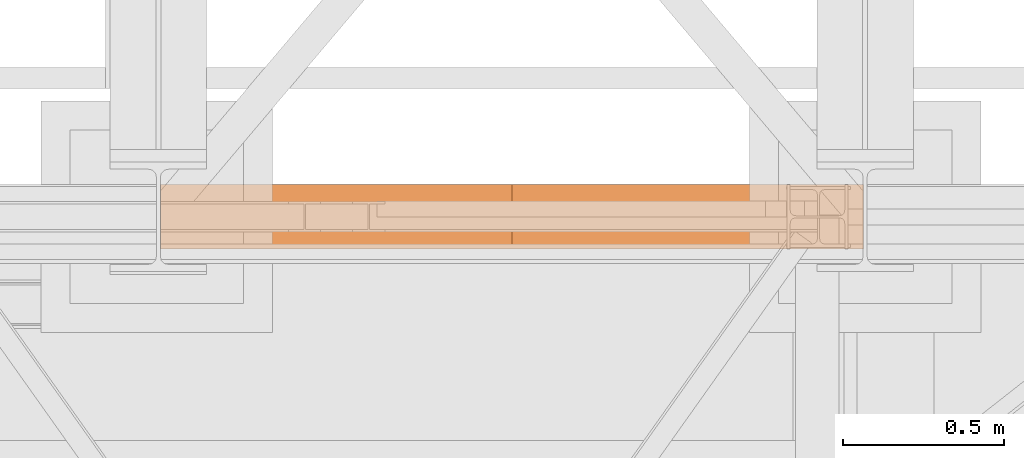
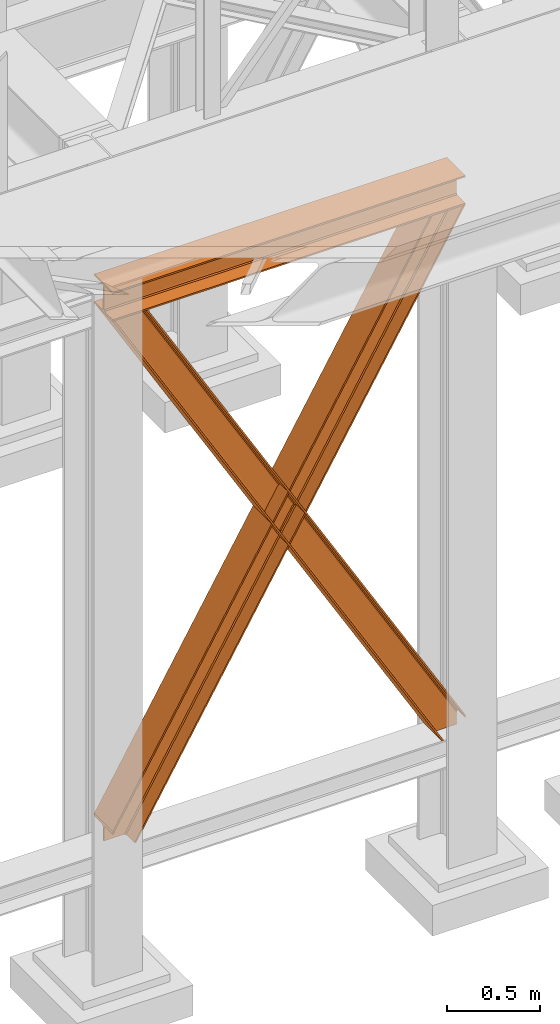
# One storey, part 71 of 208: 3 proxies.
"""IFC2X3 building model written with IfcOpenShell, lengths in millimetres."""

from ifc_helpers import new_model, entity, si_unit, converted_unit, frame, origin, origin_with_axes, place, context, subcontext, project, spatial, faceted_brep, element, save


model = new_model("IFC2X3")

# Units and contexts
model_context = context("Model", 3, precision=1e-05, world=origin())
plan_context = context("Plan", 3, precision=1e-05, world=origin())
body_context = subcontext(model_context, "Body", "Model", "MODEL_VIEW")
ifc_project = project(units=[si_unit("LENGTHUNIT", "METRE", prefix="MILLI"), converted_unit("PLANEANGLEUNIT", "DEGREE", entity("IfcPlaneAngleMeasure", 0.0174532925199433), si_unit("PLANEANGLEUNIT", "RADIAN"), dimensions=[0, 0, 0, 0, 0, 0, 0]), si_unit("AREAUNIT", "SQUARE_METRE"), si_unit("VOLUMEUNIT", "CUBIC_METRE")], contexts=[model_context, plan_context])

# Building, storey
building_placement = place(None, origin())
building = spatial("IfcBuilding", under=ifc_project, at=building_placement, CompositionType="COMPLEX")
storey_placement = place(building_placement, origin_with_axes())
storey = spatial("IfcBuildingStorey", under=building, at=storey_placement, Name="Geschoss", CompositionType="ELEMENT")

# Proxies
proxy_1_placement = place(storey_placement, frame((3300.004974593441, -17362.5323246858, 4202.989992847441), z_axis=(0.0, 0.0, 1.0), x_axis=(1.0, 0.0, 0.0)))
element("IfcBuildingElementProxy", 1, at=proxy_1_placement, inside=storey, context=body_context, shape_type="Brep", body=[
    faceted_brep([(2188.00999989569, 0.00999999999839929, 190.0100125169756), (2188.00999989569, 200.0100029802306, 190.0100125169756), (2188.00999989569, 200.0100029802306, 180.0100146031382), (2188.00999989569, 121.2600035762771, 180.0100071525576), (2188.00999989569, 111.9441915473326, 178.1454621052744), (2188.00999989569, 105.1245498640819, 171.3258190250399), (2188.00999989569, 103.2600015571697, 162.010007927418), (2188.00999989569, 103.2600015571697, 28.00999713897727), (2188.00999989569, 105.1245498640819, 18.69418604135535), (2188.00999989569, 111.9441915473326, 11.87454296112082), (2188.00999989569, 121.2600035762771, 10.00999791383765), (2188.00999989569, 200.0100029802306, 10.00999791383765), (2188.00999989569, 200.0100029802306, 0.01000000000021828), (2188.00999989569, 0.00999999999839929, 0.01000000000021828), (2188.00999989569, 0.00999999999839929, 10.00999791383765), (2188.00999989569, 78.75999940395195, 10.00999791383765), (2188.00999989569, 88.07581143289644, 11.87454296112082), (2188.00999989569, 94.89545311614711, 18.69418604135535), (2188.00999989569, 96.7600014230593, 28.00999713897727), (2188.00999989569, 96.7600014230593, 162.010007927418), (2188.00999989569, 94.89545311614711, 171.3258190250399), (2188.00999989569, 88.07581143289644, 178.1454621052744), (2188.00999989569, 78.75999940395195, 180.0100071525576), (2188.00999989569, 0.00999999999839929, 180.0100146031382), (2188.00999989569, 200.0100029802306, 190.0100125169756), (2188.00999989569, 0.00999999999839929, 190.0100125169756), (0.01000000000021828, 0.00999999999839929, 190.0100125169756), (0.01000000000021828, 200.0100029802306, 190.0100125169756), (2188.00999989569, 200.0100029802306, 180.0100146031382), (2188.00999989569, 200.0100029802306, 190.0100125169756), (0.01000000000021828, 200.0100029802306, 190.0100125169756), (0.01000000000021828, 200.0100029802306, 180.0100146031382), (2188.00999989569, 121.2600035762771, 180.0100071525576), (2188.00999989569, 200.0100029802306, 180.0100146031382), (0.01000000000021828, 200.0100029802306, 180.0100146031382), (0.01000000000021828, 121.2600035762771, 180.0100071525576), (2188.00999989569, 111.9441915473326, 178.1454621052744), (2188.00999989569, 121.2600035762771, 180.0100071525576), (0.01000000000021828, 121.2600035762771, 180.0100071525576), (0.01000000000021828, 111.9441915473326, 178.1454621052744), (2188.00999989569, 105.1245498640819, 171.3258190250399), (2188.00999989569, 111.9441915473326, 178.1454621052744), (0.01000000000021828, 111.9441915473326, 178.1454621052744), (0.01000000000021828, 105.1245498640819, 171.3258190250399), (2188.00999989569, 103.2600015571697, 162.010007927418), (2188.00999989569, 105.1245498640819, 171.3258190250399), (0.01000000000021828, 105.1245498640819, 171.3258190250399), (0.01000000000021828, 103.2600015571697, 162.010007927418), (2188.00999989569, 103.2600015571697, 28.00999713897727), (2188.00999989569, 103.2600015571697, 162.010007927418), (0.01000000000021828, 103.2600015571697, 162.010007927418), (0.01000000000021828, 103.2600015571697, 28.00999713897727), (2188.00999989569, 105.1245498640819, 18.69418604135535), (2188.00999989569, 103.2600015571697, 28.00999713897727), (0.01000000000021828, 103.2600015571697, 28.00999713897727), (0.01000000000021828, 105.1245498640819, 18.69418604135535), (2188.00999989569, 111.9441915473326, 11.87454296112082), (2188.00999989569, 105.1245498640819, 18.69418604135535), (0.01000000000021828, 105.1245498640819, 18.69418604135535), (0.01000000000021828, 111.9441915473326, 11.87454296112082), (2188.00999989569, 121.2600035762771, 10.00999791383765), (2188.00999989569, 111.9441915473326, 11.87454296112082), (0.01000000000021828, 111.9441915473326, 11.87454296112082), (0.01000000000021828, 121.2600035762771, 10.00999791383765), (2188.00999989569, 200.0100029802306, 10.00999791383765), (2188.00999989569, 121.2600035762771, 10.00999791383765), (0.01000000000021828, 121.2600035762771, 10.00999791383765), (0.01000000000021828, 200.0100029802306, 10.00999791383765), (2188.00999989569, 200.0100029802306, 0.01000000000021828), (2188.00999989569, 200.0100029802306, 10.00999791383765), (0.01000000000021828, 200.0100029802306, 10.00999791383765), (0.01000000000021828, 200.0100029802306, 0.01000000000021828), (2188.00999989569, 0.00999999999839929, 0.01000000000021828), (2188.00999989569, 200.0100029802306, 0.01000000000021828), (0.01000000000021828, 200.0100029802306, 0.01000000000021828), (0.01000000000021828, 0.00999999999839929, 0.01000000000021828), (2188.00999989569, 0.00999999999839929, 10.00999791383765), (2188.00999989569, 0.00999999999839929, 0.01000000000021828), (0.01000000000021828, 0.00999999999839929, 0.01000000000021828), (0.01000000000021828, 0.00999999999839929, 10.00999791383765), (2188.00999989569, 78.75999940395195, 10.00999791383765), (2188.00999989569, 0.00999999999839929, 10.00999791383765), (0.01000000000021828, 0.00999999999839929, 10.00999791383765), (0.01000000000021828, 78.75999940395195, 10.00999791383765), (2188.00999989569, 88.07581143289644, 11.87454296112082), (2188.00999989569, 78.75999940395195, 10.00999791383765), (0.01000000000021828, 78.75999940395195, 10.00999791383765), (0.01000000000021828, 88.07581143289644, 11.87454296112082), (2188.00999989569, 94.89545311614711, 18.69418604135535), (2188.00999989569, 88.07581143289644, 11.87454296112082), (0.01000000000021828, 88.07581143289644, 11.87454296112082), (0.01000000000021828, 94.89545311614711, 18.69418604135535), (2188.00999989569, 96.7600014230593, 28.00999713897727), (2188.00999989569, 94.89545311614711, 18.69418604135535), (0.01000000000021828, 94.89545311614711, 18.69418604135535), (0.01000000000021828, 96.7600014230593, 28.00999713897727), (2188.00999989569, 96.7600014230593, 162.010007927418), (2188.00999989569, 96.7600014230593, 28.00999713897727), (0.01000000000021828, 96.7600014230593, 28.00999713897727), (0.01000000000021828, 96.7600014230593, 162.010007927418), (2188.00999989569, 94.89545311614711, 171.3258190250399), (2188.00999989569, 96.7600014230593, 162.010007927418), (0.01000000000021828, 96.7600014230593, 162.010007927418), (0.01000000000021828, 94.89545311614711, 171.3258190250399), (2188.00999989569, 88.07581143289644, 178.1454621052744), (2188.00999989569, 94.89545311614711, 171.3258190250399), (0.01000000000021828, 94.89545311614711, 171.3258190250399), (0.01000000000021828, 88.07581143289644, 178.1454621052744), (2188.00999989569, 78.75999940395195, 180.0100071525576), (2188.00999989569, 88.07581143289644, 178.1454621052744), (0.01000000000021828, 88.07581143289644, 178.1454621052744), (0.01000000000021828, 78.75999940395195, 180.0100071525576), (2188.00999989569, 0.00999999999839929, 180.0100146031382), (2188.00999989569, 78.75999940395195, 180.0100071525576), (0.01000000000021828, 78.75999940395195, 180.0100071525576), (0.01000000000021828, 0.00999999999839929, 180.0100146031382), (2188.00999989569, 0.00999999999839929, 190.0100125169756), (2188.00999989569, 0.00999999999839929, 180.0100146031382), (0.01000000000021828, 0.00999999999839929, 180.0100146031382), (0.01000000000021828, 0.00999999999839929, 190.0100125169756), (0.01000000000021828, 0.00999999999839929, 190.0100125169756), (0.01000000000021828, 0.00999999999839929, 180.0100146031382), (0.01000000000021828, 78.75999940395195, 180.0100071525576), (0.01000000000021828, 88.07581143289644, 178.1454621052744), (0.01000000000021828, 94.89545311614711, 171.3258190250399), (0.01000000000021828, 96.7600014230593, 162.010007927418), (0.01000000000021828, 96.7600014230593, 28.00999713897727), (0.01000000000021828, 94.89545311614711, 18.69418604135535), (0.01000000000021828, 88.07581143289644, 11.87454296112082), (0.01000000000021828, 78.75999940395195, 10.00999791383765), (0.01000000000021828, 0.00999999999839929, 10.00999791383765), (0.01000000000021828, 0.00999999999839929, 0.01000000000021828), (0.01000000000021828, 200.0100029802306, 0.01000000000021828), (0.01000000000021828, 200.0100029802306, 10.00999791383765), (0.01000000000021828, 121.2600035762771, 10.00999791383765), (0.01000000000021828, 111.9441915473326, 11.87454296112082), (0.01000000000021828, 105.1245498640819, 18.69418604135535), (0.01000000000021828, 103.2600015571697, 28.00999713897727), (0.01000000000021828, 103.2600015571697, 162.010007927418), (0.01000000000021828, 105.1245498640819, 171.3258190250399), (0.01000000000021828, 111.9441915473326, 178.1454621052744), (0.01000000000021828, 121.2600035762771, 180.0100071525576), (0.01000000000021828, 200.0100029802306, 180.0100146031382), (0.01000000000021828, 200.0100029802306, 190.0100125169756)], [[[0, 1, 2, 3, 4, 5, 6, 7, 8, 9, 10, 11, 12, 13, 14, 15, 16, 17, 18, 19, 20, 21, 22, 23]], [[24, 25, 26, 27]], [[28, 29, 30, 31]], [[32, 33, 34, 35]], [[36, 37, 38, 39]], [[40, 41, 42, 43]], [[44, 45, 46, 47]], [[48, 49, 50, 51]], [[52, 53, 54, 55]], [[56, 57, 58, 59]], [[60, 61, 62, 63]], [[64, 65, 66, 67]], [[68, 69, 70, 71]], [[72, 73, 74, 75]], [[76, 77, 78, 79]], [[80, 81, 82, 83]], [[84, 85, 86, 87]], [[88, 89, 90, 91]], [[92, 93, 94, 95]], [[96, 97, 98, 99]], [[100, 101, 102, 103]], [[104, 105, 106, 107]], [[108, 109, 110, 111]], [[112, 113, 114, 115]], [[116, 117, 118, 119]], [[120, 121, 122, 123, 124, 125, 126, 127, 128, 129, 130, 131, 132, 133, 134, 135, 136, 137, 138, 139, 140, 141, 142, 143]]], orient=[[False], [False], [False], [False], [False], [False], [False], [False], [False], [False], [False], [False], [False], [False], [False], [False], [False], [False], [False], [False], [False], [False], [False], [False], [False], [False]]),
])
proxy_2_placement = place(storey_placement, frame((3300.58245655252, -17362.5323246858, 734.9900149335328), z_axis=(0.0, 0.0, 1.0), x_axis=(1.0, 0.0, 0.0)))
element("IfcBuildingElementProxy", 2, at=proxy_2_placement, inside=storey, context=body_context, shape_type="Brep", body=[
    faceted_brep([(2187.432517936612, 0.00999999999839929, 120.8497915510925), (216.8471928951321, 0.00999999999839929, 3468.009977913908), (216.8471928951321, 200.0100029802306, 3468.009977913908), (2187.432517936612, 200.0100029802306, 120.8497915510925), (2187.432517936612, 200.0100029802306, 120.8497915510925), (216.8471928951321, 200.0100029802306, 3468.009977913908), (205.4347121912169, 200.0100029802306, 3468.009977913908), (2187.432517936612, 200.0100029802306, 101.4682129393399), (2187.432517936612, 200.0100029802306, 101.4682129393399), (205.4347121912169, 200.0100029802306, 3468.009977913908), (205.4347036882541, 121.2600035762771, 3468.009977913908), (2187.432517936951, 121.2600035762771, 101.4681984983712), (2187.432517936951, 121.2600035762771, 101.4681984983712), (205.4347036882541, 121.2600035762771, 3468.009977913908), (203.306794806967, 111.9441915473326, 3468.009977913909), (2187.432602958225, 111.9441915473326, 97.8542740943027), (2187.432602958225, 111.9441915473326, 97.8542740943027), (203.306794806967, 111.9441915473326, 3468.009977913909), (195.5238886772499, 105.1245498640819, 3468.009977913908), (2187.432517936612, 105.1245498640819, 84.63689245399053), (2187.432517936612, 105.1245498640819, 84.63689245399053), (195.5238886772499, 105.1245498640819, 3468.009977913908), (184.892235020021, 103.2600015571697, 3468.009977913908), (2187.432517936612, 103.2600015571697, 66.58142866151934), (2187.432517936612, 103.2600015571697, 0.01000000000010459), (2187.432517936612, 103.2600015571697, 66.58142866151934), (184.892235020021, 103.2600015571697, 3468.009977913908), (31.96494937214857, 103.2600015571697, 3468.009977913908), (2073.723887154785, 103.2600015571697, 0.01000000000033197), (2073.723887154785, 103.2600015571697, 0.01000000000033197), (31.96494937214857, 103.2600015571697, 3468.009977913908), (21.33329571491913, 105.1245498640819, 3468.009977913908), (2063.093996904378, 105.1245498640819, 0.01000000000021828), (2063.093996904378, 105.1245498640819, 0.01000000000021828), (21.33329571491913, 105.1245498640819, 3468.009977913908), (13.55038958520254, 111.9441915473326, 3468.009977913908), (2055.312379673187, 111.9441915473326, 0.009999999999877218), (2055.312379673187, 111.9441915473326, 0.009999999999877218), (13.55038958520254, 111.9441915473326, 3468.009977913908), (11.42248070391588, 121.2600035762771, 3468.009977913907), (2053.184822892688, 121.2600035762771, 0.009999999999877218), (2053.184822892688, 121.2600035762771, 0.009999999999877218), (11.42248070391588, 121.2600035762771, 3468.009977913907), (11.42248070391634, 200.0100029802306, 3468.009977913907), (2053.184822892688, 200.0100029802306, 0.009999999999877218), (2053.184822892688, 200.0100029802306, 0.009999999999877218), (11.42248070391634, 200.0100029802306, 3468.009977913907), (0.01000000000021828, 200.0100029802306, 3468.009977913908), (2041.774228435658, 200.0100029802306, 0.01000000000010459), (2041.774228435658, 200.0100029802306, 0.01000000000010459), (0.01000000000021828, 200.0100029802306, 3468.009977913908), (0.01000000000021828, 0.00999999999839929, 3468.009977913908), (2041.774228435658, 0.00999999999839929, 0.01000000000010459), (2041.774228435658, 0.00999999999839929, 0.01000000000010459), (0.01000000000021828, 0.00999999999839929, 3468.009977913908), (11.42248070391679, 0.00999999999839929, 3468.009977913908), (2053.184822892688, 0.00999999999839929, 0.009999999999990905), (2053.184822892688, 0.00999999999839929, 0.009999999999990905), (11.42248070391679, 0.00999999999839929, 3468.009977913908), (11.42248070391634, 78.75999940395195, 3468.009977913907), (2053.184822892688, 78.75999940395195, 0.009999999999877218), (2053.184822892688, 78.75999940395195, 0.009999999999877218), (11.42248070391634, 78.75999940395195, 3468.009977913907), (13.55038958520254, 88.07581143290008, 3468.009977913908), (2055.312379673187, 88.07581143289644, 0.009999999999877218), (2055.312379673187, 88.07581143289644, 0.009999999999877218), (13.55038958520254, 88.07581143290008, 3468.009977913908), (21.33329571491913, 94.89545311614711, 3468.009977913908), (2063.093996904378, 94.89545311614711, 0.009999999999877218), (2063.093996904378, 94.89545311614711, 0.009999999999877218), (21.33329571491913, 94.89545311614711, 3468.009977913908), (31.96494937214857, 96.7600014230593, 3468.009977913908), (2073.723887154785, 96.7600014230593, 0.01000000000033197), (2073.723887154785, 96.7600014230593, 0.01000000000033197), (31.96494937214857, 96.7600014230593, 3468.009977913908), (184.892235020021, 96.7600014230593, 3468.009977913908), (2187.432517936612, 96.7600014230593, 66.581428661519), (2187.432517936612, 96.7600014230593, 0.01000000000010459), (2187.432517936612, 96.7600014230593, 66.581428661519), (184.892235020021, 96.7600014230593, 3468.009977913908), (195.5238886772499, 94.89545311614711, 3468.009977913908), (2187.432517936612, 94.89545311615075, 84.63689245399053), (2187.432517936612, 94.89545311615075, 84.63689245399053), (195.5238886772499, 94.89545311614711, 3468.009977913908), (203.306794806967, 88.07581143289644, 3468.009977913909), (2187.432517936612, 88.07581143289644, 97.85441850857103), (2187.432517936612, 88.07581143289644, 97.85441850857103), (203.306794806967, 88.07581143289644, 3468.009977913909), (205.4347036882546, 78.75999940395195, 3468.009977913908), (2187.432433072335, 78.75999940395195, 101.4683426459952), (2187.432433072335, 78.75999940395195, 101.4683426459952), (205.4347036882546, 78.75999940395195, 3468.009977913908), (205.4347121912169, 0.00999999999839929, 3468.009977913908), (2187.432517936272, 0.00999999999839929, 101.4682129399165), (2187.432517936272, 0.00999999999839929, 101.4682129399165), (205.4347121912169, 0.00999999999839929, 3468.009977913908), (216.8471928951321, 0.00999999999839929, 3468.009977913908), (2187.432517936612, 0.00999999999839929, 120.8497915510925), (216.8471928951321, 0.00999999999839929, 3468.009977913908), (205.4347121912169, 0.00999999999839929, 3468.009977913908), (205.4347036882546, 78.75999940395195, 3468.009977913908), (203.306794806967, 88.07581143289644, 3468.009977913909), (195.5238886772499, 94.89545311614711, 3468.009977913908), (184.892235020021, 96.7600014230593, 3468.009977913908), (31.96494937214857, 96.7600014230593, 3468.009977913908), (21.33329571491913, 94.89545311614711, 3468.009977913908), (13.55038958520254, 88.07581143290008, 3468.009977913908), (11.42248070391634, 78.75999940395195, 3468.009977913907), (11.42248070391679, 0.00999999999839929, 3468.009977913908), (0.01000000000021828, 0.00999999999839929, 3468.009977913908), (0.01000000000021828, 200.0100029802306, 3468.009977913908), (11.42248070391634, 200.0100029802306, 3468.009977913907), (11.42248070391588, 121.2600035762771, 3468.009977913907), (13.55038958520254, 111.9441915473326, 3468.009977913908), (21.33329571491913, 105.1245498640819, 3468.009977913908), (31.96494937214857, 103.2600015571697, 3468.009977913908), (184.892235020021, 103.2600015571697, 3468.009977913908), (195.5238886772499, 105.1245498640819, 3468.009977913908), (203.306794806967, 111.9441915473326, 3468.009977913909), (205.4347036882541, 121.2600035762771, 3468.009977913908), (205.4347121912169, 200.0100029802306, 3468.009977913908), (216.8471928951321, 200.0100029802306, 3468.009977913908), (2187.432517936612, 96.7600014230593, 0.01000000000010459), (2187.432517936612, 96.7600014230593, 66.581428661519), (2187.432517936612, 94.89545311615075, 84.63689245399053), (2187.432517936612, 88.07581143289644, 97.85441850857103), (2187.432433072335, 78.75999940395195, 101.4683426459952), (2187.432517936272, 0.00999999999839929, 101.4682129399165), (2187.432517936612, 0.00999999999839929, 120.8497915510925), (2187.432517936612, 200.0100029802306, 120.8497915510925), (2187.432517936612, 200.0100029802306, 101.4682129393399), (2187.432517936951, 121.2600035762771, 101.4681984983712), (2187.432602958225, 111.9441915473326, 97.8542740943027), (2187.432517936612, 105.1245498640819, 84.63689245399053), (2187.432517936612, 103.2600015571697, 66.58142866151934), (2187.432517936612, 103.2600015571697, 0.01000000000010459), (2073.723887154785, 103.2600015571697, 0.01000000000033197), (2063.093996904378, 105.1245498640819, 0.01000000000021828), (2055.312379673187, 111.9441915473326, 0.009999999999877218), (2053.184822892688, 121.2600035762771, 0.009999999999877218), (2053.184822892688, 200.0100029802306, 0.009999999999877218), (2041.774228435658, 200.0100029802306, 0.01000000000010459), (2041.774228435658, 0.00999999999839929, 0.01000000000010459), (2053.184822892688, 0.00999999999839929, 0.009999999999990905), (2053.184822892688, 78.75999940395195, 0.009999999999877218), (2055.312379673187, 88.07581143289644, 0.009999999999877218), (2063.093996904378, 94.89545311614711, 0.009999999999877218), (2073.723887154785, 96.7600014230593, 0.01000000000033197), (2187.432517936612, 96.7600014230593, 0.01000000000010459), (2187.432517936612, 103.2600015571697, 0.01000000000010459)], [[[0, 1, 2, 3]], [[4, 5, 6, 7]], [[8, 9, 10, 11]], [[12, 13, 14, 15]], [[16, 17, 18, 19]], [[20, 21, 22, 23]], [[24, 25, 26, 27, 28]], [[29, 30, 31, 32]], [[33, 34, 35, 36]], [[37, 38, 39, 40]], [[41, 42, 43, 44]], [[45, 46, 47, 48]], [[49, 50, 51, 52]], [[53, 54, 55, 56]], [[57, 58, 59, 60]], [[61, 62, 63, 64]], [[65, 66, 67, 68]], [[69, 70, 71, 72]], [[73, 74, 75, 76, 77]], [[78, 79, 80, 81]], [[82, 83, 84, 85]], [[86, 87, 88, 89]], [[90, 91, 92, 93]], [[94, 95, 96, 97]], [[98, 99, 100, 101, 102, 103, 104, 105, 106, 107, 108, 109, 110, 111, 112, 113, 114, 115, 116, 117, 118, 119, 120, 121]], [[122, 123, 124, 125, 126, 127, 128, 129, 130, 131, 132, 133, 134, 135]], [[136, 137, 138, 139, 140, 141, 142, 143, 144, 145, 146, 147, 148, 149]]], orient=[[False], [False], [False], [False], [False], [False], [False], [False], [False], [False], [False], [False], [False], [False], [False], [False], [False], [False], [False], [False], [False], [False], [False], [False], [False], [False], [False]]),
])
proxy_3_placement = place(storey_placement, frame((3300.004889571828, -17362.5323246858, 734.9900149335328), z_axis=(0.0, 0.0, 1.0), x_axis=(1.0, 0.0, 0.0)))
element("IfcBuildingElementProxy", 3, at=proxy_3_placement, inside=storey, context=body_context, shape_type="Brep", body=[
    faceted_brep([(0.01008502161312208, 0.00999999999839929, 120.8497915510925), (0.01008502161312208, 200.0100029802306, 120.8497915510925), (1970.595410063093, 200.0100029802306, 3468.009977913908), (1970.595410063093, 0.00999999999839929, 3468.009977913908), (0.01008502161312208, 200.0100029802306, 120.8497915510925), (0.01008502161266733, 200.0100029802306, 101.4682129393399), (1982.007890767009, 200.0100029802306, 3468.009977913908), (1970.595410063093, 200.0100029802306, 3468.009977913908), (0.01008502161266733, 200.0100029802306, 101.4682129393399), (0.01008502127388056, 121.2600035762771, 101.4681984983712), (1982.007899269971, 121.2600035762771, 3468.009977913908), (1982.007890767009, 200.0100029802306, 3468.009977913908), (0.01008502127388056, 121.2600035762771, 101.4681984983712), (0.009999999999308784, 111.9441915473326, 97.8542740943027), (1984.135808151258, 111.9441915473326, 3468.009977913909), (1982.007899269971, 121.2600035762771, 3468.009977913908), (0.009999999999308784, 111.9441915473326, 97.8542740943027), (0.01008502161312208, 105.1245498640819, 84.63689245399053), (1991.918714280975, 105.1245498640819, 3468.009977913908), (1984.135808151258, 111.9441915473326, 3468.009977913909), (0.01008502161312208, 105.1245498640819, 84.63689245399053), (0.01008502161312208, 103.2600015571697, 66.58142866151934), (2002.550367938204, 103.2600015571697, 3468.009977913908), (1991.918714280975, 105.1245498640819, 3468.009977913908), (0.01008502161312208, 103.2600015571697, 0.01000000000010459), (113.7187158034394, 103.2600015571697, 0.01000000000033197), (2155.477653586077, 103.2600015571697, 3468.009977913908), (2002.550367938204, 103.2600015571697, 3468.009977913908), (0.01008502161312208, 103.2600015571697, 66.58142866151934), (113.7187158034394, 103.2600015571697, 0.01000000000033197), (124.3486060538462, 105.1245498640819, 0.01000000000021828), (2166.109307243306, 105.1245498640819, 3468.009977913908), (2155.477653586077, 103.2600015571697, 3468.009977913908), (124.3486060538462, 105.1245498640819, 0.01000000000021828), (132.1302232850376, 111.9441915473326, 0.009999999999877218), (2173.892213373022, 111.9441915473326, 3468.009977913908), (2166.109307243306, 105.1245498640819, 3468.009977913908), (132.1302232850376, 111.9441915473326, 0.009999999999877218), (134.2577800655363, 121.2600035762771, 0.009999999999877218), (2176.020122254309, 121.2600035762771, 3468.009977913907), (2173.892213373022, 111.9441915473326, 3468.009977913908), (134.2577800655363, 121.2600035762771, 0.009999999999877218), (134.2577800655363, 200.0100029802306, 0.009999999999877218), (2176.020122254308, 200.0100029802306, 3468.009977913907), (2176.020122254309, 121.2600035762771, 3468.009977913907), (134.2577800655363, 200.0100029802306, 0.009999999999877218), (145.668374522566, 200.0100029802306, 0.01000000000010459), (2187.432602958224, 200.0100029802306, 3468.009977913908), (2176.020122254308, 200.0100029802306, 3468.009977913907), (145.668374522566, 200.0100029802306, 0.01000000000010459), (145.668374522566, 0.00999999999839929, 0.01000000000010459), (2187.432602958224, 0.00999999999839929, 3468.009977913908), (2187.432602958224, 200.0100029802306, 3468.009977913908), (145.668374522566, 0.00999999999839929, 0.01000000000010459), (134.2577800655363, 0.00999999999839929, 0.009999999999990905), (2176.020122254308, 0.00999999999839929, 3468.009977913908), (2187.432602958224, 0.00999999999839929, 3468.009977913908), (134.2577800655363, 0.00999999999839929, 0.009999999999990905), (134.2577800655363, 78.75999940395195, 0.009999999999877218), (2176.020122254308, 78.75999940395195, 3468.009977913907), (2176.020122254308, 0.00999999999839929, 3468.009977913908), (134.2577800655363, 78.75999940395195, 0.009999999999877218), (132.1302232850376, 88.07581143289644, 0.009999999999877218), (2173.892213373022, 88.07581143290008, 3468.009977913908), (2176.020122254308, 78.75999940395195, 3468.009977913907), (132.1302232850376, 88.07581143289644, 0.009999999999877218), (124.3486060538457, 94.89545311614711, 0.009999999999877218), (2166.109307243306, 94.89545311614711, 3468.009977913908), (2173.892213373022, 88.07581143290008, 3468.009977913908), (124.3486060538457, 94.89545311614711, 0.009999999999877218), (113.7187158034394, 96.7600014230593, 0.01000000000033197), (2155.477653586077, 96.7600014230593, 3468.009977913908), (2166.109307243306, 94.89545311614711, 3468.009977913908), (113.7187158034394, 96.7600014230593, 0.01000000000033197), (0.01008502161266733, 96.7600014230593, 0.01000000000010459), (0.01008502161312208, 96.7600014230593, 66.581428661519), (2002.550367938204, 96.7600014230593, 3468.009977913908), (2155.477653586077, 96.7600014230593, 3468.009977913908), (0.01008502161312208, 96.7600014230593, 66.581428661519), (0.01008502161312208, 94.89545311615075, 84.63689245399053), (1991.918714280975, 94.89545311614711, 3468.009977913908), (2002.550367938204, 96.7600014230593, 3468.009977913908), (0.01008502161312208, 94.89545311615075, 84.63689245399053), (0.01008502161312208, 88.07581143289644, 97.85441850857103), (1984.135808151258, 88.07581143289644, 3468.009977913909), (1991.918714280975, 94.89545311614711, 3468.009977913908), (0.01008502161312208, 88.07581143289644, 97.85441850857103), (0.01016988588980894, 78.75999940395195, 101.4683426459952), (1982.007899269971, 78.75999940395195, 3468.009977913908), (1984.135808151258, 88.07581143289644, 3468.009977913909), (0.01016988588980894, 78.75999940395195, 101.4683426459952), (0.0100850219523636, 0.00999999999839929, 101.4682129399165), (1982.007890767009, 0.00999999999839929, 3468.009977913908), (1982.007899269971, 78.75999940395195, 3468.009977913908), (0.0100850219523636, 0.00999999999839929, 101.4682129399165), (0.01008502161312208, 0.00999999999839929, 120.8497915510925), (1970.595410063093, 0.00999999999839929, 3468.009977913908), (1982.007890767009, 0.00999999999839929, 3468.009977913908), (1970.595410063093, 0.00999999999839929, 3468.009977913908), (1970.595410063093, 200.0100029802306, 3468.009977913908), (1982.007890767009, 200.0100029802306, 3468.009977913908), (1982.007899269971, 121.2600035762771, 3468.009977913908), (1984.135808151258, 111.9441915473326, 3468.009977913909), (1991.918714280975, 105.1245498640819, 3468.009977913908), (2002.550367938204, 103.2600015571697, 3468.009977913908), (2155.477653586077, 103.2600015571697, 3468.009977913908), (2166.109307243306, 105.1245498640819, 3468.009977913908), (2173.892213373022, 111.9441915473326, 3468.009977913908), (2176.020122254309, 121.2600035762771, 3468.009977913907), (2176.020122254308, 200.0100029802306, 3468.009977913907), (2187.432602958224, 200.0100029802306, 3468.009977913908), (2187.432602958224, 0.00999999999839929, 3468.009977913908), (2176.020122254308, 0.00999999999839929, 3468.009977913908), (2176.020122254308, 78.75999940395195, 3468.009977913907), (2173.892213373022, 88.07581143290008, 3468.009977913908), (2166.109307243306, 94.89545311614711, 3468.009977913908), (2155.477653586077, 96.7600014230593, 3468.009977913908), (2002.550367938204, 96.7600014230593, 3468.009977913908), (1991.918714280975, 94.89545311614711, 3468.009977913908), (1984.135808151258, 88.07581143289644, 3468.009977913909), (1982.007899269971, 78.75999940395195, 3468.009977913908), (1982.007890767009, 0.00999999999839929, 3468.009977913908), (0.01008502161266733, 96.7600014230593, 0.01000000000010459), (0.01008502161312208, 103.2600015571697, 0.01000000000010459), (0.01008502161312208, 103.2600015571697, 66.58142866151934), (0.01008502161312208, 105.1245498640819, 84.63689245399053), (0.009999999999308784, 111.9441915473326, 97.8542740943027), (0.01008502127388056, 121.2600035762771, 101.4681984983712), (0.01008502161266733, 200.0100029802306, 101.4682129393399), (0.01008502161312208, 200.0100029802306, 120.8497915510925), (0.01008502161312208, 0.00999999999839929, 120.8497915510925), (0.0100850219523636, 0.00999999999839929, 101.4682129399165), (0.01016988588980894, 78.75999940395195, 101.4683426459952), (0.01008502161312208, 88.07581143289644, 97.85441850857103), (0.01008502161312208, 94.89545311615075, 84.63689245399053), (0.01008502161312208, 96.7600014230593, 66.581428661519), (113.7187158034394, 103.2600015571697, 0.01000000000033197), (0.01008502161312208, 103.2600015571697, 0.01000000000010459), (0.01008502161266733, 96.7600014230593, 0.01000000000010459), (113.7187158034394, 96.7600014230593, 0.01000000000033197), (124.3486060538457, 94.89545311614711, 0.009999999999877218), (132.1302232850376, 88.07581143289644, 0.009999999999877218), (134.2577800655363, 78.75999940395195, 0.009999999999877218), (134.2577800655363, 0.00999999999839929, 0.009999999999990905), (145.668374522566, 0.00999999999839929, 0.01000000000010459), (145.668374522566, 200.0100029802306, 0.01000000000010459), (134.2577800655363, 200.0100029802306, 0.009999999999877218), (134.2577800655363, 121.2600035762771, 0.009999999999877218), (132.1302232850376, 111.9441915473326, 0.009999999999877218), (124.3486060538462, 105.1245498640819, 0.01000000000021828)], [[[0, 1, 2, 3]], [[4, 5, 6, 7]], [[8, 9, 10, 11]], [[12, 13, 14, 15]], [[16, 17, 18, 19]], [[20, 21, 22, 23]], [[24, 25, 26, 27, 28]], [[29, 30, 31, 32]], [[33, 34, 35, 36]], [[37, 38, 39, 40]], [[41, 42, 43, 44]], [[45, 46, 47, 48]], [[49, 50, 51, 52]], [[53, 54, 55, 56]], [[57, 58, 59, 60]], [[61, 62, 63, 64]], [[65, 66, 67, 68]], [[69, 70, 71, 72]], [[73, 74, 75, 76, 77]], [[78, 79, 80, 81]], [[82, 83, 84, 85]], [[86, 87, 88, 89]], [[90, 91, 92, 93]], [[94, 95, 96, 97]], [[98, 99, 100, 101, 102, 103, 104, 105, 106, 107, 108, 109, 110, 111, 112, 113, 114, 115, 116, 117, 118, 119, 120, 121]], [[122, 123, 124, 125, 126, 127, 128, 129, 130, 131, 132, 133, 134, 135]], [[136, 137, 138, 139, 140, 141, 142, 143, 144, 145, 146, 147, 148, 149]]], orient=[[False], [False], [False], [False], [False], [False], [False], [False], [False], [False], [False], [False], [False], [False], [False], [False], [False], [False], [False], [False], [False], [False], [False], [False], [False], [False], [False]]),
])

save(model, "model.ifc")
